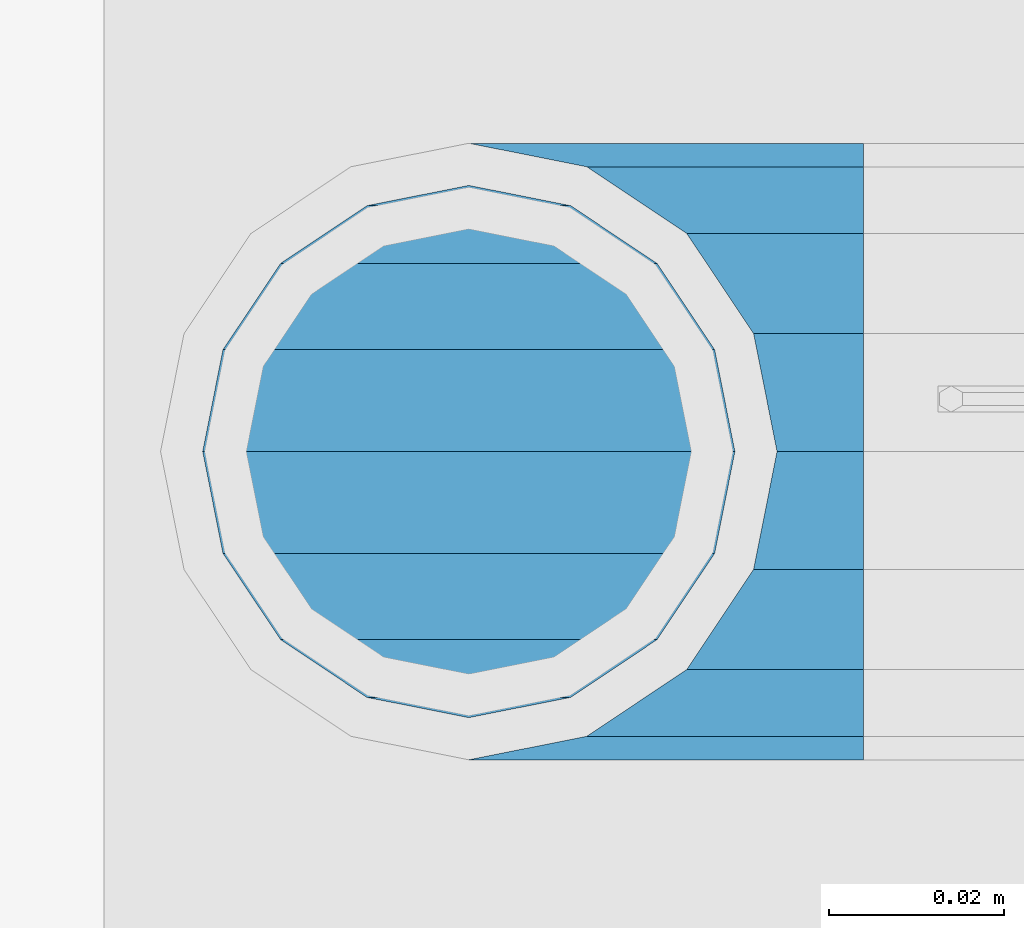
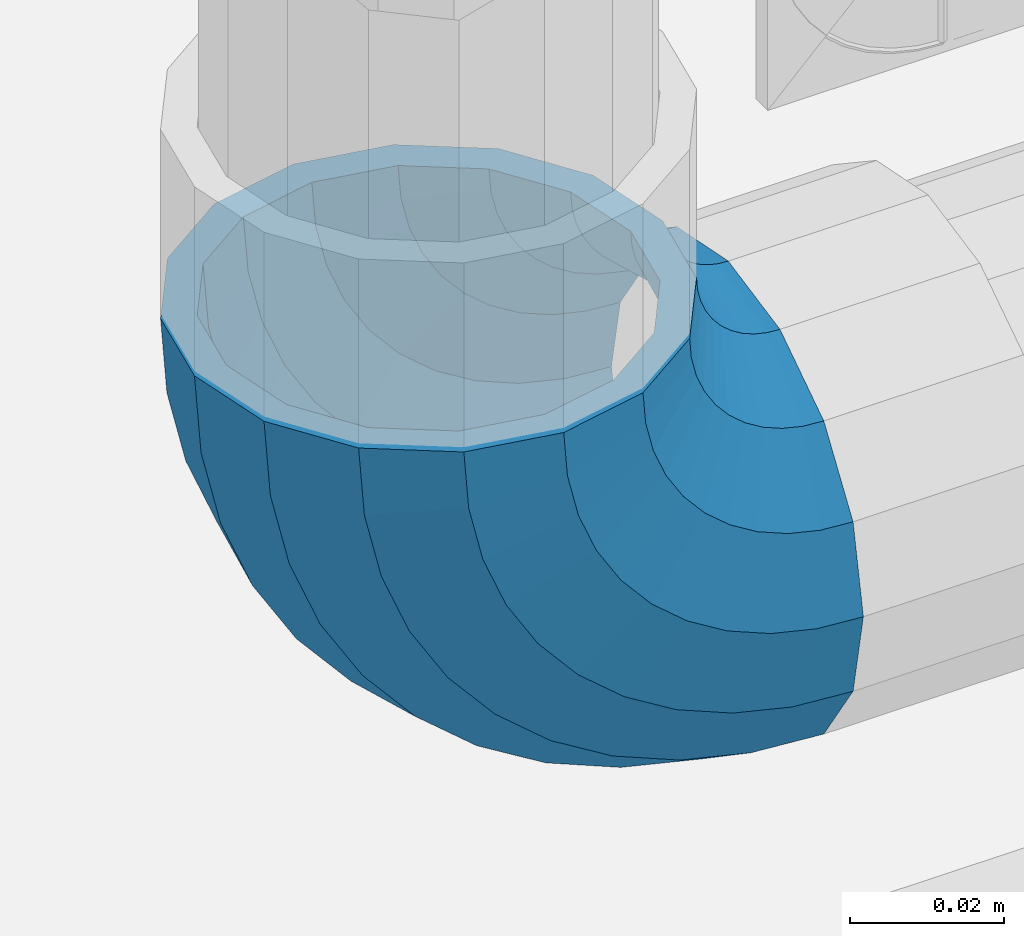
# One storey, part 160 of 240: 1 member.
"""IFC2X3 building model written with IfcOpenShell, lengths in millimetres."""

import ifcopenshell
import ifcopenshell.guid

model = None  # the IFC model being written
_history = None  # IfcOwnerHistory: only IFC2X3 demands one
_inside = {}  # id of a spatial element -> (the spatial element, [elements in it])
_under = {}  # id of a project, library or spatial element -> (it, [spatial elements below it])
_declared = {}  # id of a project -> (the project, [libraries it declares])
_typed = {}  # id of a type object -> (the type object, [elements of that type])
_made_of = {}  # id of a material, layer set ... -> (it, [elements and type objects made of it])


def new_model(schema):
    """Start an empty IFC model of exactly this schema.

    Asked for "IFC4X3", IfcOpenShell would pick the latest addendum, in which some entities
    have other attributes; the version numbers below select the first issue.
    IFC2X3 requires an IfcOwnerHistory on every rooted entity: one is made here for all.
    """
    global model, _history
    if schema == "IFC4X3":
        model = ifcopenshell.file(schema_version=(4, 3, 0, 0))
    else:
        model = ifcopenshell.file(schema=schema)
    _inside.clear()
    _under.clear()
    _declared.clear()
    _typed.clear()
    _made_of.clear()
    _history = None
    if model.schema == "IFC2X3":
        org = make("IfcOrganization", Name="unknown")
        user = make(
            "IfcPersonAndOrganization",
            ThePerson=make("IfcPerson", FamilyName="unknown"),
            TheOrganization=org,
        )
        app = make(
            "IfcApplication",
            ApplicationDeveloper=org,
            Version="unknown",
            ApplicationFullName="unknown",
            ApplicationIdentifier="unknown",
        )
        _history = make(
            "IfcOwnerHistory",
            OwningUser=user,
            OwningApplication=app,
            ChangeAction="ADDED",
            CreationDate=0,
        )
    return model


def make(cls, **values):
    """One entity of the class cls with the attributes given. An attribute that is None is left unset."""
    return model.create_entity(
        cls, **{name: value for name, value in values.items() if value is not None}
    )


def rooted(cls, **values):
    """An entity with a GlobalId (a new one), such as an element, a storey or a relation."""
    return make(cls, GlobalId=ifcopenshell.guid.new(), OwnerHistory=_history, **values)


def si_unit(unit_type, name, prefix=None):
    """IfcSIUnit, for example si_unit("LENGTHUNIT", "METRE", prefix="MILLI")."""
    return make("IfcSIUnit", UnitType=unit_type, Prefix=prefix, Name=name)


def assignment(units):
    """IfcUnitAssignment: the units of a project."""
    return None if units is None else make("IfcUnitAssignment", Units=units)


def point(xyz):
    """IfcCartesianPoint."""
    return None if xyz is None else make("IfcCartesianPoint", Coordinates=xyz)


def direction(xyz):
    """IfcDirection."""
    return None if xyz is None else make("IfcDirection", DirectionRatios=xyz)


def frame(location, z_axis=None, x_axis=None):
    """IfcAxis2Placement3D, a coordinate frame: its origin and axes. An axis left out is left unset."""
    return make(
        "IfcAxis2Placement3D",
        Location=point(location),
        Axis=direction(z_axis),
        RefDirection=direction(x_axis),
    )


def origin_with_axes():
    """The frame at (0, 0, 0) with the z axis (0, 0, 1) and the x axis (1, 0, 0) written out."""
    return frame((0.0, 0.0, 0.0), z_axis=(0.0, 0.0, 1.0), x_axis=(1.0, 0.0, 0.0))


def place(relative_to, where):
    """IfcLocalPlacement: puts the frame where relative to a parent placement (None: the world)."""
    return make(
        "IfcLocalPlacement", PlacementRelTo=relative_to, RelativePlacement=where
    )


def context(
    kind, dimensions, precision=None, world=None, true_north=None, identifier=None
):
    """IfcGeometricRepresentationContext, for example the 3D "Model" context."""
    return make(
        "IfcGeometricRepresentationContext",
        ContextIdentifier=identifier,
        ContextType=kind,
        CoordinateSpaceDimension=dimensions,
        Precision=precision,
        WorldCoordinateSystem=world,
        TrueNorth=true_north,
    )


def subcontext(parent, identifier, kind, view, scale=None):
    """IfcGeometricRepresentationSubContext, for example "Body" below "Model"."""
    return make(
        "IfcGeometricRepresentationSubContext",
        ContextIdentifier=identifier,
        ContextType=kind,
        ParentContext=parent,
        TargetScale=scale,
        TargetView=view,
    )


def project(units=None, contexts=None):
    """IfcProject with its units and contexts."""
    return rooted(
        "IfcProject",
        Name="project",
        RepresentationContexts=contexts,
        UnitsInContext=assignment(units),
    )


def spatial(cls, under=None, at=None, **own):
    """A site, building, storey or space (cls), placed at a placement, below another one or the project."""
    s = rooted(cls, ObjectPlacement=at, **own)
    if under is not None:
        _under.setdefault(under.id(), (under, []))[1].append(s)
    return s


def faces_of(points, faces, orient=None, outer=None):
    """IfcFace entities. A face is a list of loops; a loop is a list of indices into points, from 0.

    orient and outer hold one flag for each loop. By default every Orientation is true, the
    first loop of a face is its IfcFaceOuterBound and the others are IfcFaceBound.
    """
    made = []
    for i, loops in enumerate(faces):
        bounds = []
        for j, loop in enumerate(loops):
            is_outer = j == 0 if outer is None else outer[i][j]
            bounds.append(
                make(
                    "IfcFaceOuterBound" if is_outer else "IfcFaceBound",
                    Bound=make("IfcPolyLoop", Polygon=[points[k] for k in loop]),
                    Orientation=True if orient is None else orient[i][j],
                )
            )
        made.append(make("IfcFace", Bounds=bounds))
    return made


def faceted_brep(points, faces, orient=None, outer=None, voids=None):
    """IfcFacetedBrep: a solid bounded by flat faces; with voids (closed shells), ...WithVoids."""
    shared = [point(p) for p in points]
    hull = make("IfcClosedShell", CfsFaces=faces_of(shared, faces, orient, outer))
    if voids is None:
        return make("IfcFacetedBrep", Outer=hull)
    return make(
        "IfcFacetedBrepWithVoids",
        Outer=hull,
        Voids=[
            make(cls, CfsFaces=faces_of(shared, fs, o, b)) for cls, fs, o, b in voids
        ],
    )


def shape(context_of_items, identifier, shape_type, items):
    """IfcShapeRepresentation: the items that make up one representation, for example the "Body"."""
    return make(
        "IfcShapeRepresentation",
        ContextOfItems=context_of_items,
        RepresentationIdentifier=identifier,
        RepresentationType=shape_type,
        Items=items,
    )


def material(Name=None, Category=None):
    """IfcMaterial."""
    return make("IfcMaterial", Name=Name, Category=Category)


def made_of(thing, what):
    """Note that an element or type object is made of a material, layer set ...; save() writes the relation."""
    if what is not None:
        _made_of.setdefault(what.id(), (what, []))[1].append(thing)
    return thing


def type_object(cls, material=None, **own):
    """A type object (cls), such as IfcWallType, which elements share."""
    return made_of(rooted(cls, **own), material)


def element(
    cls,
    number,
    at=None,
    inside=None,
    cuts=None,
    type_object=None,
    material=None,
    context=None,
    identifier="Body",
    shape_type=None,
    held_by="IfcProductDefinitionShape",
    body=None,
    shapes=None,
    **own,
):
    """One element of the class cls, such as IfcWall. Its Tag is "e" and its number.

    at: its placement. inside: the storey or other place that contains it. cuts: it is an
    opening in that element (IfcRelVoidsElement). A single representation is given by context,
    identifier, shape_type and body (its items); several are given by shapes. held_by: the class
    of the entity that holds the representations. save() writes the other relations.
    """
    e = rooted(cls, Tag="e%d" % number, ObjectPlacement=at, **own)
    if body is not None:
        shapes = [shape(context, identifier, shape_type, body)]
    if shapes is not None:
        e.Representation = make(held_by, Representations=shapes)
    if inside is not None:
        _inside.setdefault(inside.id(), (inside, []))[1].append(e)
    if cuts is not None:
        rooted(
            "IfcRelVoidsElement", RelatingBuildingElement=cuts, RelatedOpeningElement=e
        )
    if type_object is not None:
        _typed.setdefault(type_object.id(), (type_object, []))[1].append(e)
    return made_of(e, material)


def aggregate(whole, parts):
    """IfcRelAggregates: a whole, such as a stair, and the parts it consists of."""
    return rooted("IfcRelAggregates", RelatingObject=whole, RelatedObjects=parts)


def save(model, path):
    """Write the relations noted so far, then the file.

    IfcRelAggregates (storeys below a building ...), IfcRelContainedInSpatialStructure (elements
    in a storey), IfcRelDefinesByType, IfcRelAssociatesMaterial and IfcRelDeclares: one each for
    every whole, place, type object, material and project.
    """
    for whole, parts in _under.values():
        aggregate(whole, parts)
    for where, things in _inside.values():
        rooted(
            "IfcRelContainedInSpatialStructure",
            RelatedElements=things,
            RelatingStructure=where,
        )
    for kind, things in _typed.values():
        rooted("IfcRelDefinesByType", RelatedObjects=things, RelatingType=kind)
    for what, things in _made_of.values():
        rooted("IfcRelAssociatesMaterial", RelatedObjects=things, RelatingMaterial=what)
    for by, libraries in _declared.values():
        rooted("IfcRelDeclares", RelatingContext=by, RelatedDefinitions=libraries)
    model.write(path)


model = new_model("IFC2X3")

# Units and contexts
model_context = context("Model", 3, precision=1e-05, world=origin_with_axes())
body_context = subcontext(model_context, "Body", "Model", "MODEL_VIEW")
ifc_project = project(units=[si_unit("LENGTHUNIT", "METRE", prefix="MILLI"), si_unit("AREAUNIT", "SQUARE_METRE"), si_unit("VOLUMEUNIT", "CUBIC_METRE"), si_unit("MASSUNIT", "GRAM", prefix="KILO"), si_unit("TIMEUNIT", "SECOND"), si_unit("PLANEANGLEUNIT", "RADIAN"), si_unit("SOLIDANGLEUNIT", "STERADIAN"), si_unit("THERMODYNAMICTEMPERATUREUNIT", "DEGREE_CELSIUS"), si_unit("LUMINOUSINTENSITYUNIT", "LUMEN")], contexts=[model_context])

# Site, building, storey
site_placement = place(None, origin_with_axes())
site = spatial("IfcSite", under=ifc_project, at=site_placement, CompositionType="ELEMENT")
building_placement = place(site_placement, origin_with_axes())
building = spatial("IfcBuilding", under=site, at=building_placement, Name="Standard", CompositionType="ELEMENT")
storey_placement = place(building_placement, origin_with_axes())
storey = spatial("IfcBuildingStorey", under=building, at=storey_placement, Name="Undefined", CompositionType="ELEMENT", Elevation=0.0)

# Member
ifc_material = material(Name="Misc_Undefined")
member_type = type_object("IfcMemberType", PredefinedType="NOTDEFINED")
member_placement = place(storey_placement, frame((54781.61, 34664.5, 343.170000000002), z_axis=(-0.707106781186548, 0.0, -0.707106781186548), x_axis=(0.707106781186548, 0.0, -0.707106781186548)))
element("IfcMember", 1, at=member_placement, inside=storey, type_object=member_type, material=ifc_material, context=body_context, shape_type="Brep", body=[
    faceted_brep([(0.0, -35.1500000000015, 0.0), (9.51152146006643, -32.4743655677739, -9.51152146006643), (13.2759578763362, -32.4743655677739, -6.29638902527222), (5.36946880023606, -35.1500000000015, 4.58595959348168), (17.5749999999971, -24.8548033587067, -17.5749999999971), (19.9787556631127, -24.8548033587067, -15.5219987155579), (22.9628441077002, -13.4513226476338, -22.9628441077002), (24.4574219585265, -13.4513226476338, -21.686354032383), (24.8548033587067, 0.0, -24.8548033587067), (26.0301204183124, 0.0, -23.8509877588003), (22.9628441077002, 13.4513226476338, -22.9628441077002), (24.4574219585265, 13.4513226476338, -21.686354032383), (17.5749999999971, 24.8548033587067, -17.5749999999971), (19.9787556631127, 24.8548033587067, -15.5219987155579), (9.51152146006643, 32.4743655677739, -9.51152146006643), (13.2759578763362, 32.4743655677739, -6.29638902527222), (0.0, 35.1500000000015, 0.0), (5.36946880023606, 35.1500000000015, 4.58595959348168), (-9.51152146007371, 32.4743655677739, 9.51152146007371), (-2.53702027587133, 32.4743655677739, 15.4683082122356), (-17.5749999999971, 24.8548033587067, 17.5750000000044), (-9.23981806264055, 24.8548033587067, 24.6939179025212), (-22.9628441077075, 13.4513226476338, 22.9628441077075), (-13.7184843580544, 13.4513226476338, 30.8582732193609), (-24.8548033587067, 0.0, 24.854803358714), (-15.2911828178476, 0.0, 33.0229069457637), (-22.9628441077075, -13.4513226476338, 22.9628441077075), (-13.7184843580544, -13.4513226476338, 30.8582732193609), (-17.5749999999971, -24.8548033587067, 17.5750000000044), (-9.23981806264055, -24.8548033587067, 24.6939179025212), (-9.51152146007371, -32.4743655677739, 9.51152146007371), (-2.53702027587133, -32.4743655677739, 15.4683082122356), (0.0, -30.3499999999985, 0.0), (-8.21265081971796, -28.0397438117143, 8.21265081971796), (-1.45732902223244, -28.0397438117143, 13.9822406910389), (5.36946880023606, -30.3499999999985, 4.58595959348168), (-15.1750000000029, -21.4606908090136, 15.1750000000029), (-7.24480876131565, -21.4606908090136, 21.9480231689959), (-19.8270929919963, -11.6144421722784, 19.8270929919963), (-11.1118790903492, -11.6144421722784, 27.2705888550845), (-21.4606908090136, 0.0, 21.4606908090136), (-12.46981360684, 0.0, 29.139625372758), (-19.8270929919963, 11.6144421722784, 19.8270929919963), (-11.1118790903492, 11.6144421722784, 27.2705888550845), (-15.1750000000029, 21.4606908090136, 15.1750000000029), (-7.24480876131565, 21.4606908090136, 21.9480231689959), (-8.21265081971796, 28.0397438117143, 8.21265081971796), (-1.45732902223244, 28.0397438117143, 13.9822406910389), (0.0, 30.3499999999985, 0.0), (5.36946880023606, 30.3499999999985, 4.58595959348168), (8.21265081971796, 28.0397438117143, -8.21265081971796), (12.1962666227046, 28.0397438117143, -4.81032150407555), (15.1750000000029, 21.4606908090136, -15.1749999999956), (17.9837463617805, 21.4606908090136, -12.7761039820398), (19.8270929919963, 11.6144421722784, -19.8270929919963), (21.8508166908287, 11.6144421722784, -18.0986696681139), (21.4606908090136, 0.0, -21.4606908090063), (23.2087512073122, 0.0, -19.9677061857947), (19.8270929919963, -11.6144421722784, -19.8270929919963), (21.8508166908287, -11.6144421722784, -18.0986696681139), (15.1750000000029, -21.4606908090136, -15.1749999999956), (17.9837463617805, -21.4606908090136, -12.7761039820398), (8.21265081971796, -28.0397438117143, -8.21265081971796), (12.1962666227046, -28.0397438117143, -4.81032150407555), (17.4970053560755, -32.4743655677739, -3.70972780291777), (11.390232665115, -35.1500000000015, 8.27548843508703), (22.6740772628618, -24.8548033587067, -13.8703035149447), (26.1332861179544, -13.4513226476338, -20.6593831546707), (27.347998730962, 0.0, -23.0433908901396), (26.1332861179544, 13.4513226476338, -20.6593831546707), (22.6740772628618, 24.8548033587067, -13.8703035149447), (17.4970053560755, 32.4743655677739, -3.70972780291777), (11.390232665115, 35.1500000000015, 8.27548843508703), (5.28345997416181, 32.4743655677739, 20.2607046730918), (0.106388067375519, 24.8548033587067, 30.4212803851042), (-3.35282078771706, 13.4513226476338, 37.210360024852), (-4.56753340072464, 0.0, 39.5943677603063), (-3.35282078771706, -13.4513226476338, 37.210360024852), (0.106388067375519, -24.8548033587067, 30.4212803851042), (5.28345997416181, -32.4743655677739, 20.2607046730918), (6.11738625913131, -28.0397438117143, 18.6240321853984), (11.390232665115, -30.3499999999985, 8.27548843508703), (1.64728291997744, -21.4606908090136, 27.3971039595053), (-1.33954464053386, -11.6144421722784, 33.2590831078996), (-2.38837900197541, 0.0, 35.3175364442068), (-1.33954464053386, 11.6144421722784, 33.2590831078996), (1.64728291997744, 21.4606908090136, 27.3971039595053), (6.11738625913131, 28.0397438117143, 18.6240321853984), (11.390232665115, 30.3499999999985, 8.27548843508703), (16.663079071106, 28.0397438117143, -2.07305531522434), (21.1331824102599, 21.4606908090136, -10.8461270893313), (24.1200099707639, 11.6144421722784, -16.7081062377256), (25.1688443322128, 0.0, -18.7665595740255), (24.1200099707639, -11.6144421722784, -16.7081062377256), (21.1331824102599, -21.4606908090136, -10.8461270893313), (16.663079071106, -28.0397438117143, -2.07305531522434), (22.070727701459, -32.4743655677739, -1.81522997692809), (17.9140404065256, -35.1500000000015, 10.9777380798914), (25.5945970362081, -24.8548033587067, -12.6605846156453), (27.9491712485105, -13.4513226476338, -19.9072189058861), (28.7759877588032, 0.0, -22.4518984678798), (27.9491712485105, 13.4513226476338, -19.9072189058861), (25.5945970362081, 24.8548033587067, -12.6605846156453), (22.070727701459, 32.4743655677739, -1.81522997692809), (17.9140404065256, 35.1500000000015, 10.9777380798914), (13.7573531115777, 32.4743655677739, 23.7707061367109), (10.2334837768358, 24.8548033587067, 34.6160607754209), (7.87890956454066, 13.4513226476338, 41.862695065669), (7.05209305424796, 0.0, 44.4073746276699), (7.87890956454066, -13.4513226476338, 41.862695065669), (10.2334837768358, -24.8548033587067, 34.6160607754209), (13.7573531115777, -32.4743655677739, 23.7707061367109), (14.3249803951039, -28.0397438117143, 22.023728990971), (17.9140404065256, -30.3499999999985, 10.9777380798914), (11.2823222355146, -21.4606908090136, 31.3880679180002), (9.24928305078356, -11.6144421722784, 37.6451191472734), (8.53537462724489, 0.0, 39.8423033494473), (9.24928305078356, 11.6144421722784, 37.6451191472734), (11.2823222355146, 21.4606908090136, 31.3880679180002), (14.3249803951039, 28.0397438117143, 22.023728990971), (17.9140404065256, 30.3499999999985, 10.9777380798914), (21.5031004179473, 28.0397438117143, -0.0682528311954229), (24.5457585775293, 21.4606908090136, -9.43259175821731), (26.5787977622676, 11.6144421722784, -15.6896429874905), (27.2927061858063, 0.0, -17.8868271896717), (26.5787977622676, -11.6144421722784, -15.6896429874905), (24.5457585775293, -21.4606908090136, -9.43259175821731), (21.5031004179473, -28.0397438117143, -0.0682528311954229), (26.8845046890492, -32.4743655677739, -0.659544371257653), (24.7802542265854, -35.1500000000015, 12.6261701733893), (28.6684020936882, -24.8548033587067, -11.9226293117827), (29.860364231703, -13.4513226476338, -19.4483820661189), (30.2789256727556, 0.0, -22.0910749985269), (29.860364231703, 13.4513226476338, -19.4483820661189), (28.6684020936882, 24.8548033587067, -11.9226293117827), (26.8845046890492, 32.4743655677739, -0.659544371257653), (24.7802542265854, 35.1500000000015, 12.6261701733893), (22.6760037641216, 32.4743655677739, 25.9118847180362), (20.8921063594826, 24.8548033587067, 37.1749696585684), (19.7001442214678, 13.4513226476338, 44.7007224129047), (19.2815827804225, 0.0, 47.3434153453127), (19.7001442214678, -13.4513226476338, 44.7007224129047), (20.8921063594826, -24.8548033587067, 37.1749696585684), (22.6760037641216, -32.4743655677739, 25.9118847180362), (22.9633551786319, -28.0397438117143, 24.0976192894668), (24.7802542265854, -30.3499999999985, 12.6261701733893), (21.4230625404889, -21.4606908090136, 33.8226442665691), (20.3938719035359, -11.6144421722784, 40.3206982095071), (20.0324682126156, 0.0, 42.6025113104479), (20.3938719035359, 11.6144421722784, 40.3206982095071), (21.4230625404889, 21.4606908090136, 33.8226442665691), (22.9633551786319, 28.0397438117143, 24.0976192894668), (24.7802542265854, 30.3499999999985, 12.6261701733893), (26.5971532745461, 28.0397438117143, 1.15472105731169), (28.1374459126891, 21.4606908090136, -8.57030391978333), (29.1666365496349, 11.6144421722784, -15.0683578627213), (29.5280402405551, 0.0, -17.3501709636694), (29.1666365496349, -11.6144421722784, -15.0683578627213), (28.1374459126891, -21.4606908090136, -8.57030391978333), (26.5971532745461, -28.0397438117143, 1.15472105731169), (31.8198051533982, -32.4743655677739, -0.271127801024704), (31.8198051533909, -35.1500000000015, 13.1801948466091), (31.8198051533982, -24.8548033587067, -11.6746085120976), (31.8198051533909, -13.4513226476338, -19.2941707211648), (31.8198051533982, 0.0, -21.9698051533924), (31.8198051533909, 13.4513226476338, -19.2941707211648), (31.8198051533982, 24.8548033587067, -11.6746085120976), (31.8198051533982, 32.4743655677739, -0.271127801024704), (31.8198051533909, 35.1500000000015, 13.1801948466091), (31.8198051533982, 32.4743655677739, 26.6315174942429), (31.8198051533982, 24.8548033587067, 38.0349982053158), (31.8198051533909, 13.4513226476338, 45.654560414383), (31.8198051533982, 0.0, 48.3301948466178), (31.8198051533909, -13.4513226476338, 45.654560414383), (31.8198051533982, -24.8548033587067, 38.0349982053158), (31.8198051533982, -32.4743655677739, 26.6315174942429), (31.8198051533982, -28.0397438117143, 24.7946370188947), (31.8198051533909, -30.3499999999985, 13.1801948466091), (31.8198051533982, -21.4606908090136, 34.6408856556227), (31.8198051533982, -11.6144421722784, 41.2199386583306), (31.8198051533982, 0.0, 43.5301948466076), (31.8198051533982, 11.6144421722784, 41.2199386583306), (31.8198051533982, 21.4606908090136, 34.6408856556227), (31.8198051533982, 28.0397438117143, 24.7946370188947), (31.8198051533909, 30.3499999999985, 13.1801948466091), (31.8198051533982, 28.0397438117143, 1.56575267433072), (31.8198051533982, 21.4606908090136, -8.28049596239725), (31.8198051533982, 11.6144421722784, -14.8595489651125), (31.8198051533982, 0.0, -17.1698051533895), (31.8198051533982, -11.6144421722784, -14.8595489651125), (31.8198051533982, -21.4606908090136, -8.28049596239725), (31.8198051533982, -28.0397438117143, 1.56575267433072), (36.7551056177399, -32.4743655677739, -0.659544371264928), (38.859356080211, -35.1500000000015, 12.6261701733965), (34.9712082131082, -24.8548033587067, -11.9226293117899), (33.7792460750934, -13.4513226476338, -19.4483820661189), (33.3606846340408, 0.0, -22.0910749985342), (33.7792460750934, 13.4513226476338, -19.4483820661189), (34.9712082131082, 24.8548033587067, -11.9226293117899), (36.7551056177399, 32.4743655677739, -0.659544371264928), (38.859356080211, 35.1500000000015, 12.6261701733965), (40.9636065426675, 32.4743655677739, 25.9118847180434), (42.7475039473065, 24.8548033587067, 37.1749696585684), (43.9394660853213, 13.4513226476338, 44.7007224129047), (44.3580275263739, 0.0, 47.3434153453054), (43.9394660853213, -13.4513226476338, 44.7007224129047), (42.7475039473065, -24.8548033587067, 37.1749696585684), (40.9636065426675, -32.4743655677739, 25.9118847180434), (40.6762551281645, -28.0397438117143, 24.0976192894668), (38.859356080211, -30.3499999999985, 12.6261701733965), (42.2165477663075, -21.4606908090136, 33.8226442665691), (43.2457384032605, -11.6144421722784, 40.3206982094998), (43.6071420941807, 0.0, 42.6025113104552), (43.2457384032605, 11.6144421722784, 40.3206982094998), (42.2165477663075, 21.4606908090136, 33.8226442665691), (40.6762551281645, 28.0397438117143, 24.0976192894668), (38.859356080211, 30.3499999999985, 12.6261701733965), (37.042457032243, 28.0397438117143, 1.15472105731169), (35.5021643941072, 21.4606908090136, -8.57030391978333), (34.4729737571543, 11.6144421722784, -15.068357862714), (34.111570066234, 0.0, -17.3501709636694), (34.4729737571543, -11.6144421722784, -15.068357862714), (35.5021643941072, -21.4606908090136, -8.57030391978333), (37.042457032243, -28.0397438117143, 1.15472105731169), (41.5688826053301, -32.4743655677739, -1.81522997692809), (45.7255699002708, -35.1500000000015, 10.9777380798987), (38.0450132705882, -24.8548033587067, -12.6605846156381), (35.6904390582786, -13.4513226476338, -19.9072189058934), (34.8636225479859, 0.0, -22.4518984678871), (35.6904390582786, 13.4513226476338, -19.9072189058934), (38.0450132705882, 24.8548033587067, -12.6605846156381), (41.5688826053301, 32.4743655677739, -1.81522997692809), (45.7255699002708, 35.1500000000015, 10.9777380798987), (49.8822571952041, 32.4743655677739, 23.7707061367109), (53.4061265299533, 24.8548033587067, 34.6160607754282), (55.7607007422557, 13.4513226476338, 41.862695065669), (56.5875172525484, 0.0, 44.4073746276626), (55.7607007422557, -13.4513226476338, 41.862695065669), (53.4061265299533, -24.8548033587067, 34.6160607754282), (49.8822571952041, -32.4743655677739, 23.7707061367109), (49.3146299116925, -28.0397438117143, 22.023728990971), (45.7255699002708, -30.3499999999985, 10.9777380798987), (52.3572880712745, -21.4606908090136, 31.3880679180002), (54.3903272560128, -11.6144421722784, 37.6451191472734), (55.1042356795515, 0.0, 39.8423033494473), (54.3903272560128, 11.6144421722784, 37.6451191472734), (52.3572880712745, 21.4606908090136, 31.3880679180002), (49.3146299116925, 28.0397438117143, 22.023728990971), (45.7255699002708, 30.3499999999985, 10.9777380798987), (42.1365098888491, 28.0397438117143, -0.068252831188147), (39.0938517292598, 21.4606908090136, -9.43259175821731), (37.0608125445287, 11.6144421722784, -15.6896429874905), (36.3469041209901, 0.0, -17.8868271896645), (37.0608125445287, -11.6144421722784, -15.6896429874905), (39.0938517292598, -21.4606908090136, -9.43259175821731), (42.1365098888491, -28.0397438117143, -0.068252831188147), (46.1426049507209, -32.4743655677739, -3.70972780291777), (52.2493776416741, -35.1500000000015, 8.27548843508703), (40.9655330439346, -24.8548033587067, -13.8703035149374), (37.506324188842, -13.4513226476338, -20.6593831546707), (36.2916115758271, 0.0, -23.0433908901323), (37.506324188842, 13.4513226476338, -20.6593831546707), (40.9655330439346, 24.8548033587067, -13.8703035149374), (46.1426049507209, 32.4743655677739, -3.70972780291777), (52.2493776416741, 35.1500000000015, 8.27548843508703), (58.3561503326346, 32.4743655677739, 20.2607046730918), (63.5332222394209, 24.8548033587067, 30.4212803851115), (66.9924310945134, 13.4513226476338, 37.2103600248447), (68.207143707521, 0.0, 39.5943677603063), (66.9924310945134, -13.4513226476338, 37.2103600248447), (63.5332222394209, -24.8548033587067, 30.4212803851115), (58.3561503326346, -32.4743655677739, 20.2607046730918), (57.5222240476651, -28.0397438117143, 18.6240321853984), (52.2493776416741, -30.3499999999985, 8.27548843508703), (61.9923273868189, -21.4606908090136, 27.3971039594981), (64.979154947323, -11.6144421722784, 33.2590831078924), (66.0279893087718, 0.0, 35.3175364442068), (64.979154947323, 11.6144421722784, 33.2590831078924), (61.9923273868189, 21.4606908090136, 27.3971039594981), (57.5222240476651, 28.0397438117143, 18.6240321853984), (52.2493776416741, 30.3499999999985, 8.27548843508703), (46.9765312356903, 28.0397438117143, -2.07305531523161), (42.5064278965365, 21.4606908090136, -10.8461270893313), (39.5196003360252, 11.6144421722784, -16.7081062377256), (38.4707659745836, 0.0, -18.7665595740327), (39.5196003360252, -11.6144421722784, -16.7081062377256), (42.5064278965365, -21.4606908090136, -10.8461270893313), (46.9765312356903, -28.0397438117143, -2.07305531523161), (50.3636524304529, -32.4743655677739, -6.2963890252795), (58.2701415065603, -35.1500000000015, 4.58595959348895), (43.6608546436837, -24.8548033587067, -15.5219987155579), (39.1821883482698, -13.4513226476338, -21.6863540323902), (37.6094898884767, 0.0, -23.8509877587931), (39.1821883482698, 13.4513226476338, -21.6863540323902), (43.6608546436837, 24.8548033587067, -15.5219987155579), (50.3636524304529, 32.4743655677739, -6.2963890252795), (58.2701415065603, 35.1500000000015, 4.58595959348895), (66.1766305826604, 32.4743655677739, 15.4683082122356), (72.8794283694297, 24.8548033587067, 24.6939179025212), (77.3580946648508, 13.4513226476338, 30.8582732193536), (78.9307931246367, 0.0, 33.0229069457637), (77.3580946648508, -13.4513226476338, 30.8582732193536), (72.8794283694297, -24.8548033587067, 24.6939179025212), (66.1766305826604, -32.4743655677739, 15.4683082122356), (65.0969393290288, -28.0397438117143, 13.9822406910462), (58.2701415065603, -30.3499999999985, 4.58595959348895), (70.884419068112, -21.4606908090136, 21.9480231689959), (74.7514893971456, -11.6144421722784, 27.2705888550845), (76.1094239136364, 0.0, 29.139625372758), (74.7514893971456, 11.6144421722784, 27.2705888550845), (70.884419068112, 21.4606908090136, 21.9480231689959), (65.0969393290288, 28.0397438117143, 13.9822406910462), (58.2701415065603, 30.3499999999985, 4.58595959348895), (51.4433436840845, 28.0397438117143, -4.81032150407555), (45.6558639450086, 21.4606908090136, -12.7761039820325), (41.7887936159677, 11.6144421722784, -18.0986696681211), (40.4308590994842, 0.0, -19.9677061858019), (41.7887936159677, -11.6144421722784, -18.0986696681211), (45.6558639450086, -21.4606908090136, -12.7761039820325), (51.4433436840845, -28.0397438117143, -4.81032150407555), (54.1280888467154, -32.4743655677739, -9.51152146006643), (63.6396103067891, -35.1500000000015, 7.27595761418343e-12), (46.0646103067847, -24.8548033587067, -17.5749999999971), (40.6767661990889, -13.4513226476338, -22.9628441077002), (38.7848069480824, 0.0, -24.8548033586994), (40.6767661990889, 13.4513226476338, -22.9628441077002), (46.0646103067847, 24.8548033587067, -17.5749999999971), (54.1280888467154, 32.4743655677739, -9.51152146006643), (63.6396103067891, 35.1500000000015, 7.27595761418343e-12), (73.1511317668555, 32.4743655677739, 9.51152146007371), (81.2146103067862, 24.8548033587067, 17.5750000000044), (86.6024544144893, 13.4513226476338, 22.9628441077075), (88.4944136654958, 0.0, 24.854803358714), (86.6024544144893, -13.4513226476338, 22.9628441077075), (81.2146103067862, -24.8548033587067, 17.5750000000044), (73.1511317668555, -32.4743655677739, 9.51152146007371), (71.8522611265071, -28.0397438117143, 8.21265081972524), (63.6396103067891, -30.3499999999985, 7.27595761418343e-12), (78.8146103067847, -21.4606908090136, 15.1750000000029), (83.4667032987854, -11.6144421722784, 19.8270929920036), (85.1003011158027, 0.0, 21.4606908090136), (83.4667032987854, 11.6144421722784, 19.8270929920036), (78.8146103067847, 21.4606908090136, 15.1750000000029), (71.8522611265071, 28.0397438117143, 8.21265081972524), (63.6396103067891, 30.3499999999985, 7.27595761418343e-12), (55.4269594870711, 28.0397438117143, -8.21265081971069), (48.4646103067862, 21.4606908090136, -15.1749999999956), (43.8125173147855, 11.6144421722784, -19.8270929919963), (42.1789194977755, 0.0, -21.4606908090063), (43.8125173147855, -11.6144421722784, -19.8270929919963), (48.4646103067862, -21.4606908090136, -15.1749999999956), (55.4269594870711, -28.0397438117143, -8.21265081971069)], [[[0, 1, 2, 3]], [[1, 4, 5, 2]], [[4, 6, 7, 5]], [[6, 8, 9, 7]], [[8, 10, 11, 9]], [[10, 12, 13, 11]], [[12, 14, 15, 13]], [[14, 16, 17, 15]], [[16, 18, 19, 17]], [[18, 20, 21, 19]], [[20, 22, 23, 21]], [[22, 24, 25, 23]], [[24, 26, 27, 25]], [[26, 28, 29, 27]], [[28, 30, 31, 29]], [[30, 0, 3, 31]], [[32, 33, 34, 35]], [[33, 36, 37, 34]], [[36, 38, 39, 37]], [[38, 40, 41, 39]], [[40, 42, 43, 41]], [[42, 44, 45, 43]], [[44, 46, 47, 45]], [[46, 48, 49, 47]], [[48, 50, 51, 49]], [[50, 52, 53, 51]], [[52, 54, 55, 53]], [[54, 56, 57, 55]], [[56, 58, 59, 57]], [[58, 60, 61, 59]], [[60, 62, 63, 61]], [[62, 32, 35, 63]], [[30, 28, 26, 24, 22, 20, 18, 16, 14, 12, 10, 8, 6, 4, 1, 0], [62, 60, 58, 56, 54, 52, 50, 48, 46, 44, 42, 40, 38, 36, 33, 32]], [[3, 2, 64, 65]], [[2, 5, 66, 64]], [[5, 7, 67, 66]], [[7, 9, 68, 67]], [[9, 11, 69, 68]], [[11, 13, 70, 69]], [[13, 15, 71, 70]], [[15, 17, 72, 71]], [[17, 19, 73, 72]], [[19, 21, 74, 73]], [[21, 23, 75, 74]], [[23, 25, 76, 75]], [[25, 27, 77, 76]], [[27, 29, 78, 77]], [[29, 31, 79, 78]], [[31, 3, 65, 79]], [[35, 34, 80, 81]], [[34, 37, 82, 80]], [[37, 39, 83, 82]], [[39, 41, 84, 83]], [[41, 43, 85, 84]], [[43, 45, 86, 85]], [[45, 47, 87, 86]], [[47, 49, 88, 87]], [[49, 51, 89, 88]], [[51, 53, 90, 89]], [[53, 55, 91, 90]], [[55, 57, 92, 91]], [[57, 59, 93, 92]], [[59, 61, 94, 93]], [[61, 63, 95, 94]], [[63, 35, 81, 95]], [[65, 64, 96, 97]], [[64, 66, 98, 96]], [[66, 67, 99, 98]], [[67, 68, 100, 99]], [[68, 69, 101, 100]], [[69, 70, 102, 101]], [[70, 71, 103, 102]], [[71, 72, 104, 103]], [[72, 73, 105, 104]], [[73, 74, 106, 105]], [[74, 75, 107, 106]], [[75, 76, 108, 107]], [[76, 77, 109, 108]], [[77, 78, 110, 109]], [[78, 79, 111, 110]], [[79, 65, 97, 111]], [[81, 80, 112, 113]], [[80, 82, 114, 112]], [[82, 83, 115, 114]], [[83, 84, 116, 115]], [[84, 85, 117, 116]], [[85, 86, 118, 117]], [[86, 87, 119, 118]], [[87, 88, 120, 119]], [[88, 89, 121, 120]], [[89, 90, 122, 121]], [[90, 91, 123, 122]], [[91, 92, 124, 123]], [[92, 93, 125, 124]], [[93, 94, 126, 125]], [[94, 95, 127, 126]], [[95, 81, 113, 127]], [[97, 96, 128, 129]], [[96, 98, 130, 128]], [[98, 99, 131, 130]], [[99, 100, 132, 131]], [[100, 101, 133, 132]], [[101, 102, 134, 133]], [[102, 103, 135, 134]], [[103, 104, 136, 135]], [[104, 105, 137, 136]], [[105, 106, 138, 137]], [[106, 107, 139, 138]], [[107, 108, 140, 139]], [[108, 109, 141, 140]], [[109, 110, 142, 141]], [[110, 111, 143, 142]], [[111, 97, 129, 143]], [[113, 112, 144, 145]], [[112, 114, 146, 144]], [[114, 115, 147, 146]], [[115, 116, 148, 147]], [[116, 117, 149, 148]], [[117, 118, 150, 149]], [[118, 119, 151, 150]], [[119, 120, 152, 151]], [[120, 121, 153, 152]], [[121, 122, 154, 153]], [[122, 123, 155, 154]], [[123, 124, 156, 155]], [[124, 125, 157, 156]], [[125, 126, 158, 157]], [[126, 127, 159, 158]], [[127, 113, 145, 159]], [[129, 128, 160, 161]], [[128, 130, 162, 160]], [[130, 131, 163, 162]], [[131, 132, 164, 163]], [[132, 133, 165, 164]], [[133, 134, 166, 165]], [[134, 135, 167, 166]], [[135, 136, 168, 167]], [[136, 137, 169, 168]], [[137, 138, 170, 169]], [[138, 139, 171, 170]], [[139, 140, 172, 171]], [[140, 141, 173, 172]], [[141, 142, 174, 173]], [[142, 143, 175, 174]], [[143, 129, 161, 175]], [[145, 144, 176, 177]], [[144, 146, 178, 176]], [[146, 147, 179, 178]], [[147, 148, 180, 179]], [[148, 149, 181, 180]], [[149, 150, 182, 181]], [[150, 151, 183, 182]], [[151, 152, 184, 183]], [[152, 153, 185, 184]], [[153, 154, 186, 185]], [[154, 155, 187, 186]], [[155, 156, 188, 187]], [[156, 157, 189, 188]], [[157, 158, 190, 189]], [[158, 159, 191, 190]], [[159, 145, 177, 191]], [[161, 160, 192, 193]], [[160, 162, 194, 192]], [[162, 163, 195, 194]], [[163, 164, 196, 195]], [[164, 165, 197, 196]], [[165, 166, 198, 197]], [[166, 167, 199, 198]], [[167, 168, 200, 199]], [[168, 169, 201, 200]], [[169, 170, 202, 201]], [[170, 171, 203, 202]], [[171, 172, 204, 203]], [[172, 173, 205, 204]], [[173, 174, 206, 205]], [[174, 175, 207, 206]], [[175, 161, 193, 207]], [[177, 176, 208, 209]], [[176, 178, 210, 208]], [[178, 179, 211, 210]], [[179, 180, 212, 211]], [[180, 181, 213, 212]], [[181, 182, 214, 213]], [[182, 183, 215, 214]], [[183, 184, 216, 215]], [[184, 185, 217, 216]], [[185, 186, 218, 217]], [[186, 187, 219, 218]], [[187, 188, 220, 219]], [[188, 189, 221, 220]], [[189, 190, 222, 221]], [[190, 191, 223, 222]], [[191, 177, 209, 223]], [[193, 192, 224, 225]], [[192, 194, 226, 224]], [[194, 195, 227, 226]], [[195, 196, 228, 227]], [[196, 197, 229, 228]], [[197, 198, 230, 229]], [[198, 199, 231, 230]], [[199, 200, 232, 231]], [[200, 201, 233, 232]], [[201, 202, 234, 233]], [[202, 203, 235, 234]], [[203, 204, 236, 235]], [[204, 205, 237, 236]], [[205, 206, 238, 237]], [[206, 207, 239, 238]], [[207, 193, 225, 239]], [[209, 208, 240, 241]], [[208, 210, 242, 240]], [[210, 211, 243, 242]], [[211, 212, 244, 243]], [[212, 213, 245, 244]], [[213, 214, 246, 245]], [[214, 215, 247, 246]], [[215, 216, 248, 247]], [[216, 217, 249, 248]], [[217, 218, 250, 249]], [[218, 219, 251, 250]], [[219, 220, 252, 251]], [[220, 221, 253, 252]], [[221, 222, 254, 253]], [[222, 223, 255, 254]], [[223, 209, 241, 255]], [[225, 224, 256, 257]], [[224, 226, 258, 256]], [[226, 227, 259, 258]], [[227, 228, 260, 259]], [[228, 229, 261, 260]], [[229, 230, 262, 261]], [[230, 231, 263, 262]], [[231, 232, 264, 263]], [[232, 233, 265, 264]], [[233, 234, 266, 265]], [[234, 235, 267, 266]], [[235, 236, 268, 267]], [[236, 237, 269, 268]], [[237, 238, 270, 269]], [[238, 239, 271, 270]], [[239, 225, 257, 271]], [[241, 240, 272, 273]], [[240, 242, 274, 272]], [[242, 243, 275, 274]], [[243, 244, 276, 275]], [[244, 245, 277, 276]], [[245, 246, 278, 277]], [[246, 247, 279, 278]], [[247, 248, 280, 279]], [[248, 249, 281, 280]], [[249, 250, 282, 281]], [[250, 251, 283, 282]], [[251, 252, 284, 283]], [[252, 253, 285, 284]], [[253, 254, 286, 285]], [[254, 255, 287, 286]], [[255, 241, 273, 287]], [[257, 256, 288, 289]], [[256, 258, 290, 288]], [[258, 259, 291, 290]], [[259, 260, 292, 291]], [[260, 261, 293, 292]], [[261, 262, 294, 293]], [[262, 263, 295, 294]], [[263, 264, 296, 295]], [[264, 265, 297, 296]], [[265, 266, 298, 297]], [[266, 267, 299, 298]], [[267, 268, 300, 299]], [[268, 269, 301, 300]], [[269, 270, 302, 301]], [[270, 271, 303, 302]], [[271, 257, 289, 303]], [[273, 272, 304, 305]], [[272, 274, 306, 304]], [[274, 275, 307, 306]], [[275, 276, 308, 307]], [[276, 277, 309, 308]], [[277, 278, 310, 309]], [[278, 279, 311, 310]], [[279, 280, 312, 311]], [[280, 281, 313, 312]], [[281, 282, 314, 313]], [[282, 283, 315, 314]], [[283, 284, 316, 315]], [[284, 285, 317, 316]], [[285, 286, 318, 317]], [[286, 287, 319, 318]], [[287, 273, 305, 319]], [[289, 288, 320, 321]], [[288, 290, 322, 320]], [[290, 291, 323, 322]], [[291, 292, 324, 323]], [[292, 293, 325, 324]], [[293, 294, 326, 325]], [[294, 295, 327, 326]], [[295, 296, 328, 327]], [[296, 297, 329, 328]], [[297, 298, 330, 329]], [[298, 299, 331, 330]], [[299, 300, 332, 331]], [[300, 301, 333, 332]], [[301, 302, 334, 333]], [[302, 303, 335, 334]], [[303, 289, 321, 335]], [[305, 304, 336, 337]], [[304, 306, 338, 336]], [[306, 307, 339, 338]], [[307, 308, 340, 339]], [[308, 309, 341, 340]], [[309, 310, 342, 341]], [[310, 311, 343, 342]], [[311, 312, 344, 343]], [[312, 313, 345, 344]], [[313, 314, 346, 345]], [[314, 315, 347, 346]], [[315, 316, 348, 347]], [[316, 317, 349, 348]], [[317, 318, 350, 349]], [[318, 319, 351, 350]], [[319, 305, 337, 351]], [[322, 323, 324, 325, 326, 327, 328, 329, 330, 331, 332, 333, 334, 335, 321, 320], [338, 339, 340, 341, 342, 343, 344, 345, 346, 347, 348, 349, 350, 351, 337, 336]]]),
])

save(model, "model.ifc")
